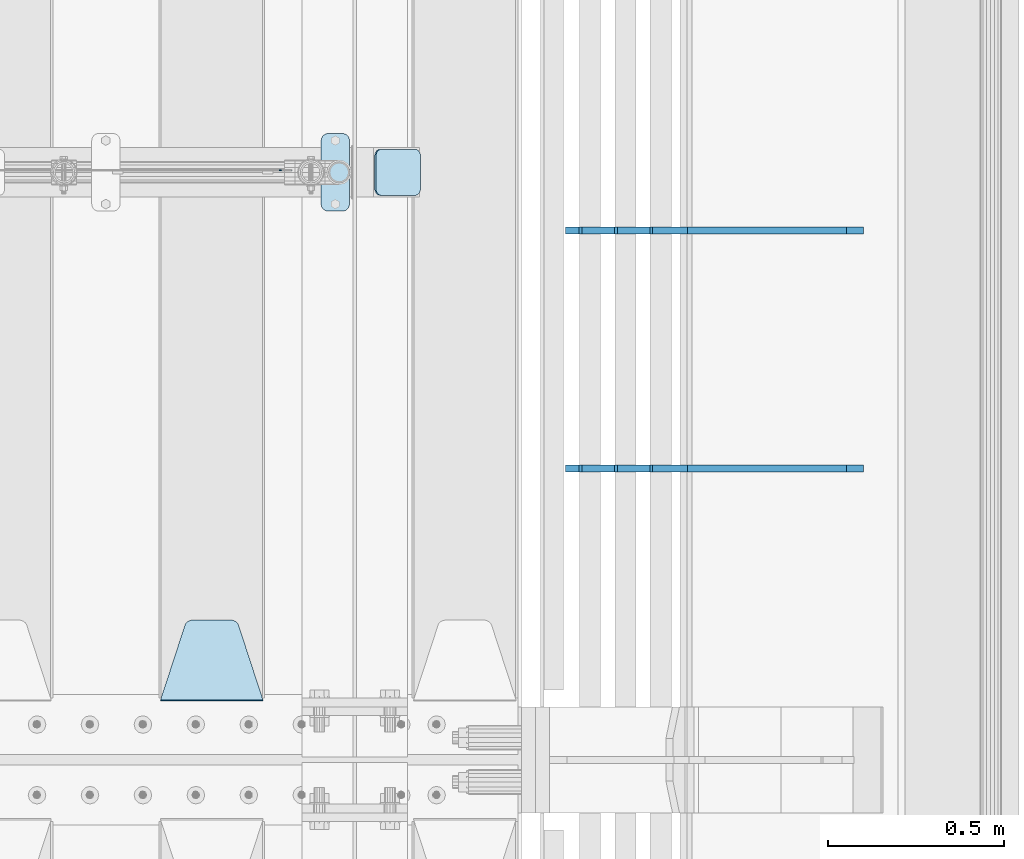
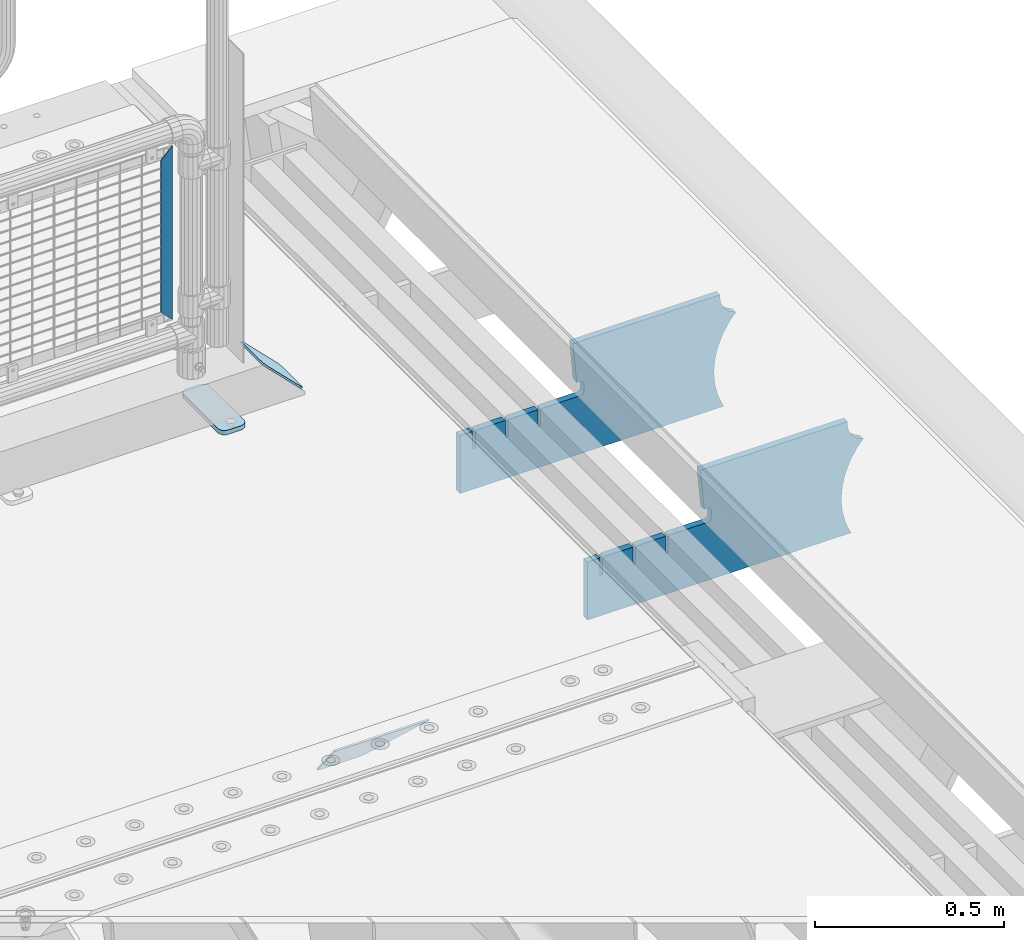
# One storey, part 223 of 240: 6 plates.
"""IFC2X3 building model written with IfcOpenShell, lengths in millimetres."""

from ifc_helpers import new_model, si_unit, frame, origin_with_axes, place, context, subcontext, project, spatial, faceted_brep, material, type_object, element, save


model = new_model("IFC2X3")

# Units and contexts
model_context = context("Model", 3, precision=1e-05, world=origin_with_axes())
body_context = subcontext(model_context, "Body", "Model", "MODEL_VIEW")
ifc_project = project(units=[si_unit("LENGTHUNIT", "METRE", prefix="MILLI"), si_unit("AREAUNIT", "SQUARE_METRE"), si_unit("VOLUMEUNIT", "CUBIC_METRE"), si_unit("MASSUNIT", "GRAM", prefix="KILO"), si_unit("TIMEUNIT", "SECOND"), si_unit("PLANEANGLEUNIT", "RADIAN"), si_unit("SOLIDANGLEUNIT", "STERADIAN"), si_unit("THERMODYNAMICTEMPERATUREUNIT", "DEGREE_CELSIUS"), si_unit("LUMINOUSINTENSITYUNIT", "LUMEN")], contexts=[model_context])

# Site, building, storey
site_placement = place(None, origin_with_axes())
site = spatial("IfcSite", under=ifc_project, at=site_placement, CompositionType="ELEMENT")
building_placement = place(site_placement, origin_with_axes())
building = spatial("IfcBuilding", under=site, at=building_placement, Name="Standard", CompositionType="ELEMENT")
storey_placement = place(building_placement, origin_with_axes())
storey = spatial("IfcBuildingStorey", under=building, at=storey_placement, Name="Undefined", CompositionType="ELEMENT", Elevation=0.0)

# Plates
ifc_material_1 = material(Name="STEEL/S355N")
plate_type_1 = type_object("IfcPlateType", PredefinedType="NOTDEFINED")
plate_1_placement = place(storey_placement, frame((55745.0, 33168.232233047, -1.76776695296758), z_axis=(0.0, 0.707106781186547, -0.707106781186548), x_axis=(-1.0, 0.0, 0.0)))
element("IfcPlate", 1, at=plate_1_placement, inside=storey, type_object=plate_type_1, material=ifc_material_1, context=body_context, shape_type="Brep", body=[
    faceted_brep([(0.0, -2.5, 0.0), (69.345504679477, -2.50000000000364, 300.171731424827), (69.345504679477, 2.49999999999636, 300.171731424827), (0.0, 2.5, 0.0), (70.927406119954, -2.50000000000364, 304.897442415397), (70.927406119954, 2.49999999999636, 304.897442415397), (73.3818627772271, -2.50000000000728, 309.234538108525), (73.3818627772271, 2.49999999999636, 309.234538108529), (76.6187032999587, -2.50000000000728, 313.023683126099), (76.6187032999587, 2.49999999999636, 313.023683126103), (80.5190132705029, -2.50000000000364, 316.125672595368), (80.5190132705029, 2.49999999999636, 316.125672595368), (84.9395038596849, -2.50000000000364, 318.426546230472), (84.9395038596849, 2.49999999999636, 318.426546230472), (89.7177759439219, -2.5, 319.841774983277), (89.7177759439219, 2.49999999999636, 319.841774983273), (94.6782862926484, -2.50000000000364, 320.319366455074), (94.6782862926484, 2.49999999999636, 320.319366455074), (195.321713707352, -2.50000000000364, 320.319366455074), (195.321713707352, 2.49999999999636, 320.319366455074), (200.282224056078, -2.50000000000364, 319.841774983273), (200.282224056078, 2.49999999999636, 319.841774983273), (205.060496140315, -2.50000000000364, 318.426546230472), (205.060496140315, 2.49999999999636, 318.426546230472), (209.480986729497, -2.50000000000364, 316.125672595368), (209.480986729497, 2.49999999999636, 316.125672595368), (213.381296700041, -2.50000000000728, 313.023683126099), (213.381296700041, 2.49999999999272, 313.023683126099), (216.618137222766, -2.50000000000364, 309.234538108522), (216.618137222766, 2.49999999999636, 309.234538108522), (219.072593880039, -2.50000000000364, 304.897442415397), (219.072593880039, 2.49999999999636, 304.897442415397), (220.654495320523, -2.50000000000364, 300.171731424827), (220.654495320523, 2.49999999999636, 300.171731424827), (290.0, -2.50000000000364, -3.63797880709171e-12), (290.0, 2.49999999999636, -3.63797880709171e-12)], [[[0, 1, 2, 3]], [[1, 4, 5, 2]], [[4, 6, 7, 5]], [[6, 8, 9, 7]], [[8, 10, 11, 9]], [[10, 12, 13, 11]], [[12, 14, 15, 13]], [[14, 16, 17, 15]], [[16, 18, 19, 17]], [[18, 20, 21, 19]], [[20, 22, 23, 21]], [[22, 24, 25, 23]], [[24, 26, 27, 25]], [[26, 28, 29, 27]], [[28, 30, 31, 29]], [[30, 32, 33, 31]], [[32, 34, 35, 33]], [[34, 0, 3, 35]], [[5, 7, 9, 11, 13, 15, 17, 19, 21, 23, 25, 27, 29, 31, 33, 35, 3, 2]], [[34, 32, 30, 28, 26, 24, 22, 20, 18, 16, 14, 12, 10, 8, 6, 4, 1, 0]]]),
])
ifc_material_2 = material(Name="STEEL/S355J2")
plate_type_2 = type_object("IfcPlateType", PredefinedType="NOTDEFINED")
plate_2_placement = place(storey_placement, frame((55910.0, 34774.5, 21.0199999999977), z_axis=(1.0, 0.0, 0.0), x_axis=(0.0, -1.0, 0.0)))
element("IfcPlate", 2, at=plate_2_placement, inside=storey, type_object=plate_type_2, material=ifc_material_2, context=body_context, shape_type="Brep", body=[
    faceted_brep([(0.0, -7.0, 20.0), (0.0, -7.0, 60.0), (0.0, 7.0, 60.0), (0.0, 7.0, 20.0), (0.384294391937146, -7.0, 63.9018064403208), (0.384294391937146, 7.0, 63.9018064403208), (1.52240934977453, -7.0, 67.6536686473046), (1.52240934977453, 7.0, 67.6536686473046), (3.37060775394639, -7.0, 71.1114046603907), (3.37060775394639, 7.0, 71.1114046603907), (5.85786437626666, -7.0, 74.1421356237333), (5.85786437626666, 7.0, 74.1421356237333), (8.88859533960931, -7.0, 76.6293922460536), (8.88859533960931, 7.0, 76.6293922460536), (12.3463313526954, -7.0, 78.4775906502255), (12.3463313526954, 7.0, 78.4775906502255), (16.0981935596792, -7.0, 79.6157056080629), (16.0981935596792, 7.0, 79.6157056080629), (20.0, -7.0, 80.0), (20.0, 7.0, 80.0), (200.0, -7.0, 80.0), (200.0, 7.0, 80.0), (203.901806440321, -7.0, 79.6157056080629), (203.901806440321, 7.0, 79.6157056080629), (207.653668647305, -7.0, 78.4775906502255), (207.653668647305, 7.0, 78.4775906502255), (211.111404660391, -7.0, 76.6293922460536), (211.111404660391, 7.0, 76.6293922460536), (214.142135623733, -7.0, 74.1421356237333), (214.142135623733, 7.0, 74.1421356237333), (216.629392246054, -7.0, 71.1114046603907), (216.629392246054, 7.0, 71.1114046603907), (218.477590650225, -7.0, 67.6536686473046), (218.477590650225, 7.0, 67.6536686473046), (219.615705608063, -7.0, 63.9018064403208), (219.615705608063, 7.0, 63.9018064403208), (220.0, -7.0, 60.0), (220.0, 7.0, 60.0), (220.0, -7.0, 20.0), (220.0, 7.0, 20.0), (219.615705608063, -7.0, 16.0981935596792), (219.615705608063, 7.0, 16.0981935596792), (218.477590650225, -7.0, 12.3463313526954), (218.477590650225, 7.0, 12.3463313526954), (216.629392246054, -7.0, 8.88859533960931), (216.629392246054, 7.0, 8.88859533960931), (214.142135623733, -7.0, 5.85786437626666), (214.142135623733, 7.0, 5.85786437626666), (211.111404660391, -7.0, 3.37060775394639), (211.111404660391, 7.0, 3.37060775394639), (207.653668647305, -7.0, 1.52240934977453), (207.653668647305, 7.0, 1.52240934977453), (203.901806440321, -7.0, 0.384294391937146), (203.901806440321, 7.0, 0.384294391937146), (200.0, -7.0, 0.0), (200.0, 7.0, 0.0), (20.0, -7.0, 0.0), (20.0, 7.0, 0.0), (16.0981935596792, -7.0, 0.384294391937146), (16.0981935596792, 7.0, 0.384294391937146), (12.3463313526954, -7.0, 1.52240934977453), (12.3463313526954, 7.0, 1.52240934977453), (8.88859533960931, -7.0, 3.37060775394639), (8.88859533960931, 7.0, 3.37060775394639), (5.85786437626666, -7.0, 5.85786437626666), (5.85786437626666, 7.0, 5.85786437626666), (3.37060775394639, -7.0, 8.88859533960931), (3.37060775394639, 7.0, 8.88859533960931), (1.52240934977453, -7.0, 12.3463313526954), (1.52240934977453, 7.0, 12.3463313526954), (0.384294391937146, -7.0, 16.0981935596792), (0.384294391937146, 7.0, 16.0981935596792)], [[[0, 1, 2, 3]], [[1, 4, 5, 2]], [[4, 6, 7, 5]], [[6, 8, 9, 7]], [[8, 10, 11, 9]], [[10, 12, 13, 11]], [[12, 14, 15, 13]], [[14, 16, 17, 15]], [[16, 18, 19, 17]], [[18, 20, 21, 19]], [[20, 22, 23, 21]], [[22, 24, 25, 23]], [[24, 26, 27, 25]], [[26, 28, 29, 27]], [[28, 30, 31, 29]], [[30, 32, 33, 31]], [[32, 34, 35, 33]], [[34, 36, 37, 35]], [[36, 38, 39, 37]], [[38, 40, 41, 39]], [[40, 42, 43, 41]], [[42, 44, 45, 43]], [[44, 46, 47, 45]], [[46, 48, 49, 47]], [[48, 50, 51, 49]], [[50, 52, 53, 51]], [[52, 54, 55, 53]], [[54, 56, 57, 55]], [[56, 58, 59, 57]], [[58, 60, 61, 59]], [[60, 62, 63, 61]], [[62, 64, 65, 63]], [[64, 66, 67, 65]], [[66, 68, 69, 67]], [[68, 70, 71, 69]], [[70, 0, 3, 71]], [[5, 7, 9, 11, 13, 15, 17, 19, 21, 23, 25, 27, 29, 31, 33, 35, 37, 39, 41, 43, 45, 47, 49, 51, 53, 55, 57, 59, 61, 63, 65, 67, 69, 71, 3, 2]], [[70, 68, 66, 64, 62, 60, 58, 56, 54, 52, 50, 48, 46, 44, 42, 40, 38, 36, 34, 32, 30, 28, 26, 24, 22, 20, 18, 16, 14, 12, 10, 8, 6, 4, 1, 0]]]),
])
plate_type_3 = type_object("IfcPlateType", PredefinedType="NOTDEFINED")
plate_3_placement = place(storey_placement, frame((56063.1924184789, 34729.5, 166.254400376664), z_axis=(0.707410512925779, 0.0, -0.70680291892584), x_axis=(0.0, -1.0, 0.0)))
element("IfcPlate", 3, at=plate_3_placement, inside=storey, type_object=plate_type_3, material=ifc_material_2, context=body_context, shape_type="Brep", body=[
    faceted_brep([(0.0, -2.5, 20.0), (0.0, -2.5, 158.926651000977), (0.0, 2.50000000000728, 158.926651000969), (0.0, 2.5, 19.9999999999927), (0.384294391937146, -2.50000000000728, 162.828457441297), (0.384294391937146, 2.5, 162.828457441297), (1.52240934977453, -2.5, 166.580319648274), (1.52240934977453, 2.50000000000728, 166.580319648274), (3.37060775394639, -2.5, 170.038055661367), (3.37060775394639, 2.5, 170.038055661367), (5.85786437626666, -2.49999999999272, 173.068786624703), (5.85786437626666, 2.5, 173.068786624703), (8.88859533960931, -2.5, 175.556043247023), (8.88859533960931, 2.50000000000728, 175.556043247023), (12.3463313526954, -2.5, 177.404241651195), (12.3463313526954, 2.50000000000728, 177.404241651195), (16.0981935596792, -2.5, 178.542356609039), (16.0981935596792, 2.50000000000728, 178.542356609039), (20.0, -2.5, 178.926651000977), (20.0, 2.5, 178.926651000977), (110.0, -2.5, 178.926651000977), (110.0, 2.5, 178.926651000977), (113.901806440321, -2.5, 178.542356609039), (113.901806440321, 2.50000000000728, 178.542356609039), (117.653668647305, -2.5, 177.404241651195), (117.653668647305, 2.50000000000728, 177.404241651195), (121.111404660391, -2.5, 175.556043247023), (121.111404660391, 2.50000000000728, 175.556043247023), (124.142135623733, -2.49999999999272, 173.068786624703), (124.142135623733, 2.5, 173.068786624703), (126.629392246054, -2.5, 170.038055661367), (126.629392246054, 2.5, 170.038055661367), (128.477590650225, -2.5, 166.580319648274), (128.477590650225, 2.50000000000728, 166.580319648274), (129.615705608063, -2.50000000000728, 162.828457441297), (129.615705608063, 2.5, 162.828457441297), (130.0, -2.5, 158.926651000977), (130.0, 2.50000000000728, 158.926651000969), (130.0, -2.5, 20.0), (130.0, 2.5, 19.9999999999927), (129.615705608063, -2.5, 16.0981935596719), (129.615705608063, 2.50000000000728, 16.0981935596719), (128.477590650225, -2.50000000000728, 12.3463313527027), (128.477590650225, 2.5, 12.3463313526954), (126.629392246054, -2.49999999999272, 8.88859533960931), (126.629392246054, 2.5, 8.88859533960931), (124.142135623733, -2.49999999999272, 5.85786437626666), (124.142135623733, 2.5, 5.85786437626666), (121.111404660391, -2.5, 3.37060775394639), (121.111404660391, 2.5, 3.37060775393911), (117.653668647305, -2.5, 1.52240934976726), (117.653668647305, 2.5, 1.52240934977453), (113.901806440321, -2.5, 0.38429439192987), (113.901806440321, 2.5, 0.38429439192987), (110.0, -2.5, 0.0), (110.0, 2.5, 0.0), (20.0, -2.5, 0.0), (20.0, 2.5, 0.0), (16.0981935596792, -2.5, 0.38429439192987), (16.0981935596792, 2.5, 0.38429439192987), (12.3463313526954, -2.5, 1.52240934976726), (12.3463313526954, 2.5, 1.52240934977453), (8.88859533960931, -2.5, 3.37060775394639), (8.88859533960931, 2.5, 3.37060775393911), (5.85786437626666, -2.49999999999272, 5.85786437626666), (5.85786437626666, 2.5, 5.85786437626666), (3.37060775394639, -2.49999999999272, 8.88859533960931), (3.37060775394639, 2.5, 8.88859533960931), (1.52240934977453, -2.5, 12.3463313526954), (1.52240934977453, 2.5, 12.3463313526954), (0.384294391937146, -2.5, 16.0981935596719), (0.384294391937146, 2.50000000000728, 16.0981935596719)], [[[0, 1, 2, 3]], [[1, 4, 5, 2]], [[4, 6, 7, 5]], [[6, 8, 9, 7]], [[8, 10, 11, 9]], [[10, 12, 13, 11]], [[12, 14, 15, 13]], [[14, 16, 17, 15]], [[16, 18, 19, 17]], [[18, 20, 21, 19]], [[20, 22, 23, 21]], [[22, 24, 25, 23]], [[24, 26, 27, 25]], [[26, 28, 29, 27]], [[28, 30, 31, 29]], [[30, 32, 33, 31]], [[32, 34, 35, 33]], [[34, 36, 37, 35]], [[36, 38, 39, 37]], [[38, 40, 41, 39]], [[40, 42, 43, 41]], [[42, 44, 45, 43]], [[44, 46, 47, 45]], [[46, 48, 49, 47]], [[48, 50, 51, 49]], [[50, 52, 53, 51]], [[52, 54, 55, 53]], [[54, 56, 57, 55]], [[56, 58, 59, 57]], [[58, 60, 61, 59]], [[60, 62, 63, 61]], [[62, 64, 65, 63]], [[64, 66, 67, 65]], [[66, 68, 69, 67]], [[68, 70, 71, 69]], [[70, 0, 3, 71]], [[5, 7, 9, 11, 13, 15, 17, 19, 21, 23, 25, 27, 29, 31, 33, 35, 37, 39, 41, 43, 45, 47, 49, 51, 53, 55, 57, 59, 61, 63, 65, 67, 69, 71, 3, 2]], [[70, 68, 66, 64, 62, 60, 58, 56, 54, 52, 50, 48, 46, 44, 42, 40, 38, 36, 34, 32, 30, 28, 26, 24, 22, 20, 18, 16, 14, 12, 10, 8, 6, 4, 1, 0]]]),
])
ifc_material_3 = material(Name="Misc_Undefined")
plate_type_4 = type_object("IfcPlateType", PredefinedType="NOTDEFINED")
plate_4_placement = place(storey_placement, frame((55826.4999999862, 34670.4997788013, 914.461469028507), z_axis=(0.706514791587334, 1.29999971174141e-08, -0.707698275586641), x_axis=(-0.707698275586609, 0.0, -0.706514791587367)))
element("IfcPlate", 4, at=plate_4_placement, inside=storey, type_object=plate_type_4, material=ifc_material_3, context=body_context, shape_type="Brep", body=[
    faceted_brep([(-7.27595761418343e-12, -1.49999999999272, 0.0), (397.726470947244, -1.5, 398.39270019532), (397.726470947237, 1.5, 398.392700195313), (0.0, 1.50000000000728, 0.0), (397.767883300759, -1.5, 348.895263671875), (397.767883300759, 1.5, 348.895263671875), (49.4561042785572, -1.5, -5.0931703299284e-11), (49.4561042785572, 1.5, -5.0931703299284e-11)], [[[0, 1, 2, 3]], [[1, 4, 5, 2]], [[4, 6, 7, 5]], [[6, 0, 3, 7]], [[5, 7, 3, 2]], [[6, 4, 1, 0]]]),
])
plate_type_5 = type_object("IfcPlateType", PredefinedType="NOTDEFINED")
plate_5_placement = place(storey_placement, frame((57442.9182339676, 33824.9992828369, -374.002067436516), z_axis=(0.0, 0.0, 1.0), x_axis=(-1.0, 0.0, 0.0)))
element("IfcPlate", 5, at=plate_5_placement, inside=storey, type_object=plate_type_5, material=ifc_material_1, context=body_context, shape_type="Brep", body=[
    faceted_brep([(801.919404066546, -10.0, 188.0), (801.919404066546, 10.0, 188.0), (801.919404066546, 10.0, 132.002067436952), (801.919404066546, -10.0, 132.002067436952), (793.919404066546, 10.0, 132.002067436952), (793.919404066546, -10.0, 132.002067436952), (793.919404066546, 10.0, 180.002067436952), (793.919404066546, -10.0, 180.002067436952), (793.52785619691, 10.0, 182.474203391951), (793.52785619691, -10.0, 182.474203391951), (792.391540021548, 10.0, 184.704349455291), (792.391540021548, -10.0, 184.704349455291), (790.621686084887, 10.0, 186.474203391951), (790.621686084887, -10.0, 186.474203391951), (788.391540021548, 10.0, 187.610519567313), (788.391540021548, -10.0, 187.610519567313), (785.919404066546, -10.0, 188.002067436952), (785.919404066546, 10.0, 188.0), (841.0, -10.0, 188.0), (841.0, -10.0, 0.0), (841.0, 10.0, 0.0), (841.0, 10.0, 188.0), (33.3619566735943, -10.0, 0.0), (33.3619566735943, 10.0, 0.0), (36.2350612208102, -10.0, 4.68848050267013), (36.2350612208102, 10.0, 4.68848050267013), (51.4877592159319, -10.0, 41.5117508652784), (51.4877592159319, 10.0, 41.5117508652784), (60.7922425881334, -10.0, 80.2677133162964), (60.7922425881334, 10.0, 80.2677133162964), (63.9194040769653, -10.0, 120.002067436515), (63.9194040769653, 10.0, 120.002067436515), (60.7922425881334, -10.0, 159.736421556734), (60.7922425881334, 10.0, 159.736421556734), (51.4877592159319, -10.0, 198.492384007752), (51.4877592159319, 10.0, 198.492384007752), (36.2350612208102, -10.0, 235.31565437036), (36.2350612208102, 10.0, 235.31565437036), (15.4097206482038, -10.0, 269.299521518803), (15.4097206482038, 10.0, 269.299521518803), (-3.35474438100209, -10.0, 291.269887256574), (-3.35474438100209, 10.0, 291.269887256574), (-2.36881039375294, -10.0000000000036, 291.426043859339), (-2.36881039375294, 10.0, 291.426043859339), (17.1449676604752, -10.0000000000036, 301.368810393754), (17.1449676604752, 10.0, 301.368810393754), (32.6311896062471, -10.0000000000036, 316.855032339527), (32.6311896062471, 10.0, 316.855032339527), (42.573956140659, -10.0000000000036, 336.368810393754), (42.573956140659, 10.0, 336.368810393754), (46.0, -10.0000000000036, 358.0), (46.0, 10.0, 358.0), (45.0495205499246, -10.0, 364.001091067617), (45.0495205499246, 10.0, 364.001091067617), (495.040008544922, -10.0, 364.010009765625), (495.040008544922, 10.0, 364.010009765625), (483.600036621094, -10.0, 233.759994506836), (483.600036621094, 10.0, 233.759994506836), (472.0, -10.0, 233.759994506836), (472.0, 10.0, 233.759994506836), (468.909830056247, -10.0, 233.270559669787), (468.909830056247, 10.0, 233.270559669787), (466.122147477072, -10.0, 231.850164450585), (466.122147477072, 10.0, 231.850164450585), (463.909830056247, -10.0, 229.637847029761), (463.909830056247, 10.0, 229.637847029761), (462.489434837051, -10.0, 226.850164450585), (462.489434837051, 10.0, 226.850164450585), (462.0, -10.0, 223.759994506836), (462.0, 10.0, 223.759994506836), (462.0, -10.0, 198.0), (462.0, 10.0, 198.0), (462.489434837051, -10.0, 194.909830056251), (462.489434837051, 10.0, 194.909830056251), (463.909830056247, -10.0, 192.122147477075), (463.909830056247, 10.0, 192.122147477075), (466.122147477072, -10.0, 189.909830056251), (466.122147477072, 10.0, 189.909830056251), (468.909830056247, -10.0, 188.489434837048), (468.909830056247, 10.0, 188.489434837048), (472.0, -10.0, 188.0), (472.0, 10.0, 188.0), (585.919404066546, -10.0, 188.002067436952), (585.919404066546, 10.0, 188.0), (588.391540021548, -9.99999999999636, 187.610519567313), (588.391540021548, 10.0, 187.610519567313), (590.621686084887, -9.99999999999636, 186.474203391951), (590.621686084887, 10.0, 186.474203391951), (592.391540021548, -9.99999999999636, 184.704349455291), (592.391540021548, 10.0, 184.704349455291), (593.52785619691, -9.99999999999636, 182.474203391951), (593.52785619691, 10.0, 182.474203391951), (593.919404066546, -9.99999999999636, 180.002067436952), (593.919404066546, 10.0, 180.002067436952), (593.919404066546, -9.99999999999636, 132.002067436952), (593.919404066546, 10.0, 132.002067436952), (601.919404066546, -9.99999999999636, 132.002067436952), (601.919404066546, 10.0, 132.002067436952), (601.919404066546, -10.0, 188.0), (601.919404066546, 10.0, 188.0), (685.919404066546, -10.0, 188.002067436952), (685.919404066546, 10.0, 188.0), (688.391540021548, -10.0, 187.610519567313), (688.391540021548, 10.0, 187.610519567313), (690.621686084887, -10.0, 186.474203391951), (690.621686084887, 10.0, 186.474203391951), (692.391540021548, -10.0, 184.704349455291), (692.391540021548, 10.0, 184.704349455291), (693.52785619691, -10.0, 182.474203391951), (693.52785619691, 10.0, 182.474203391951), (693.919404066546, -10.0, 180.002067436952), (693.919404066546, 10.0, 180.002067436952), (693.919404066546, -10.0, 132.002067436952), (693.919404066546, 10.0000000000036, 132.002067436952), (701.919404066546, -10.0, 132.002067436952), (701.919404066546, 10.0000000000036, 132.002067436952), (701.919404066546, -10.0, 188.0), (701.919404066546, 10.0, 188.0)], [[[0, 1, 2, 3]], [[3, 2, 4, 5]], [[5, 4, 6, 7]], [[7, 6, 8, 9]], [[9, 8, 10, 11]], [[11, 10, 12, 13]], [[13, 12, 14, 15]], [[16, 15, 14, 17]], [[18, 19, 20, 21]], [[20, 19, 22, 23]], [[22, 24, 25, 23]], [[26, 27, 25, 24]], [[28, 29, 27, 26]], [[30, 31, 29, 28]], [[32, 33, 31, 30]], [[34, 35, 33, 32]], [[36, 37, 35, 34]], [[38, 39, 37, 36]], [[39, 38, 40, 41]], [[40, 42, 43, 41]], [[44, 45, 43, 42]], [[46, 47, 45, 44]], [[48, 49, 47, 46]], [[50, 51, 49, 48]], [[52, 53, 51, 50]], [[54, 55, 53, 52]], [[54, 56, 57, 55]], [[56, 58, 59, 57]], [[58, 60, 61, 59]], [[60, 62, 63, 61]], [[62, 64, 65, 63]], [[64, 66, 67, 65]], [[66, 68, 69, 67]], [[68, 70, 71, 69]], [[70, 72, 73, 71]], [[72, 74, 75, 73]], [[74, 76, 77, 75]], [[76, 78, 79, 77]], [[78, 80, 81, 79]], [[81, 80, 82, 83]], [[82, 84, 85, 83]], [[86, 87, 85, 84]], [[88, 89, 87, 86]], [[90, 91, 89, 88]], [[92, 93, 91, 90]], [[94, 95, 93, 92]], [[96, 97, 95, 94]], [[98, 99, 97, 96]], [[99, 98, 100, 101]], [[100, 102, 103, 101]], [[104, 105, 103, 102]], [[106, 107, 105, 104]], [[108, 109, 107, 106]], [[110, 111, 109, 108]], [[112, 113, 111, 110]], [[114, 115, 113, 112]], [[116, 117, 115, 114]], [[117, 116, 16, 17]], [[12, 10, 8, 6, 4, 2, 1, 21, 20, 23, 25, 27, 29, 31, 33, 35, 37, 39, 41, 43, 45, 47, 49, 51, 53, 55, 57, 59, 61, 63, 65, 67, 69, 71, 73, 75, 77, 79, 81, 83, 85, 87, 89, 91, 93, 95, 97, 99, 101, 103, 105, 107, 109, 111, 113, 115, 117, 17, 14]], [[18, 21, 1, 0]], [[116, 114, 112, 110, 108, 106, 104, 102, 100, 98, 96, 94, 92, 90, 88, 86, 84, 82, 80, 78, 76, 74, 72, 70, 68, 66, 64, 62, 60, 58, 56, 54, 52, 50, 48, 46, 44, 42, 40, 38, 36, 34, 32, 30, 28, 26, 24, 22, 19, 18, 0, 3, 5, 7, 9, 11, 13, 15, 16]]]),
])
plate_6_placement = place(storey_placement, frame((57442.9182339676, 34499.9992828369, -374.002067436516), z_axis=(0.0, 0.0, 1.0), x_axis=(-1.0, 0.0, 0.0)))
element("IfcPlate", 6, at=plate_6_placement, inside=storey, type_object=plate_type_5, material=ifc_material_1, context=body_context, shape_type="Brep", body=[
    faceted_brep([(801.919404066546, -10.0, 188.0), (801.919404066546, 10.0, 188.0), (801.919404066546, 10.0, 132.002067436952), (801.919404066546, -10.0, 132.002067436952), (793.919404066546, 10.0, 132.002067436952), (793.919404066546, -10.0, 132.002067436952), (793.919404066546, 10.0, 180.002067436952), (793.919404066546, -10.0, 180.002067436952), (793.52785619691, 10.0, 182.474203391951), (793.52785619691, -10.0, 182.474203391951), (792.391540021548, 10.0, 184.704349455291), (792.391540021548, -10.0, 184.704349455291), (790.621686084887, 10.0, 186.474203391951), (790.621686084887, -10.0, 186.474203391951), (788.391540021548, 10.0, 187.610519567313), (788.391540021548, -10.0, 187.610519567313), (785.919404066546, -10.0, 188.002067436952), (785.919404066546, 10.0, 188.0), (841.0, -10.0, 188.0), (841.0, -10.0, 0.0), (841.0, 10.0, 0.0), (841.0, 10.0, 188.0), (33.3619566735943, -10.0, 0.0), (33.3619566735943, 10.0, 0.0), (36.2350612208102, -10.0, 4.68848050267013), (36.2350612208102, 10.0, 4.68848050267013), (51.4877592159319, -10.0, 41.5117508652784), (51.4877592159319, 10.0, 41.5117508652784), (60.7922425881334, -10.0, 80.2677133162964), (60.7922425881334, 10.0, 80.2677133162964), (63.9194040769653, -10.0, 120.002067436515), (63.9194040769653, 10.0, 120.002067436515), (60.7922425881334, -10.0, 159.736421556734), (60.7922425881334, 10.0, 159.736421556734), (51.4877592159319, -10.0, 198.492384007752), (51.4877592159319, 10.0, 198.492384007752), (36.2350612208102, -10.0, 235.31565437036), (36.2350612208102, 10.0, 235.31565437036), (15.4097206482038, -10.0, 269.299521518803), (15.4097206482038, 10.0, 269.299521518803), (-3.35474438100209, -10.0, 291.269887256574), (-3.35474438100209, 10.0, 291.269887256574), (-2.36881039375294, -10.0000000000036, 291.426043859339), (-2.36881039375294, 10.0, 291.426043859339), (17.1449676604752, -10.0000000000036, 301.368810393754), (17.1449676604752, 10.0, 301.368810393754), (32.6311896062471, -10.0000000000036, 316.855032339527), (32.6311896062471, 10.0, 316.855032339527), (42.573956140659, -10.0000000000036, 336.368810393754), (42.573956140659, 10.0, 336.368810393754), (46.0, -10.0000000000036, 358.0), (46.0, 10.0, 358.0), (45.0495205499246, -10.0, 364.001091067617), (45.0495205499246, 10.0, 364.001091067617), (495.040008544922, -10.0, 364.010009765625), (495.040008544922, 10.0, 364.010009765625), (483.600036621094, -10.0, 233.759994506836), (483.600036621094, 10.0, 233.759994506836), (472.0, -10.0, 233.759994506836), (472.0, 10.0, 233.759994506836), (468.909830056247, -10.0, 233.270559669787), (468.909830056247, 10.0, 233.270559669787), (466.122147477072, -10.0, 231.850164450585), (466.122147477072, 10.0, 231.850164450585), (463.909830056247, -10.0, 229.637847029761), (463.909830056247, 10.0, 229.637847029761), (462.489434837051, -10.0, 226.850164450585), (462.489434837051, 10.0, 226.850164450585), (462.0, -10.0, 223.759994506836), (462.0, 10.0, 223.759994506836), (462.0, -10.0, 198.0), (462.0, 10.0, 198.0), (462.489434837051, -10.0, 194.909830056251), (462.489434837051, 10.0, 194.909830056251), (463.909830056247, -10.0, 192.122147477075), (463.909830056247, 10.0, 192.122147477075), (466.122147477072, -10.0, 189.909830056251), (466.122147477072, 10.0, 189.909830056251), (468.909830056247, -10.0, 188.489434837048), (468.909830056247, 10.0, 188.489434837048), (472.0, -10.0, 188.0), (472.0, 10.0, 188.0), (585.919404066546, -10.0, 188.002067436952), (585.919404066546, 10.0, 188.0), (588.391540021548, -9.99999999999636, 187.610519567313), (588.391540021548, 10.0, 187.610519567313), (590.621686084887, -9.99999999999636, 186.474203391951), (590.621686084887, 10.0, 186.474203391951), (592.391540021548, -9.99999999999636, 184.704349455291), (592.391540021548, 10.0, 184.704349455291), (593.52785619691, -9.99999999999636, 182.474203391951), (593.52785619691, 10.0, 182.474203391951), (593.919404066546, -9.99999999999636, 180.002067436952), (593.919404066546, 10.0, 180.002067436952), (593.919404066546, -9.99999999999636, 132.002067436952), (593.919404066546, 10.0, 132.002067436952), (601.919404066546, -9.99999999999636, 132.002067436952), (601.919404066546, 10.0, 132.002067436952), (601.919404066546, -10.0, 188.0), (601.919404066546, 10.0, 188.0), (685.919404066546, -10.0, 188.002067436952), (685.919404066546, 10.0, 188.0), (688.391540021548, -10.0, 187.610519567313), (688.391540021548, 10.0, 187.610519567313), (690.621686084887, -10.0, 186.474203391951), (690.621686084887, 10.0, 186.474203391951), (692.391540021548, -10.0, 184.704349455291), (692.391540021548, 10.0, 184.704349455291), (693.52785619691, -10.0, 182.474203391951), (693.52785619691, 10.0, 182.474203391951), (693.919404066546, -10.0, 180.002067436952), (693.919404066546, 10.0, 180.002067436952), (693.919404066546, -10.0, 132.002067436952), (693.919404066546, 10.0000000000036, 132.002067436952), (701.919404066546, -10.0, 132.002067436952), (701.919404066546, 10.0000000000036, 132.002067436952), (701.919404066546, -10.0, 188.0), (701.919404066546, 10.0, 188.0)], [[[0, 1, 2, 3]], [[3, 2, 4, 5]], [[5, 4, 6, 7]], [[7, 6, 8, 9]], [[9, 8, 10, 11]], [[11, 10, 12, 13]], [[13, 12, 14, 15]], [[16, 15, 14, 17]], [[18, 19, 20, 21]], [[20, 19, 22, 23]], [[22, 24, 25, 23]], [[26, 27, 25, 24]], [[28, 29, 27, 26]], [[30, 31, 29, 28]], [[32, 33, 31, 30]], [[34, 35, 33, 32]], [[36, 37, 35, 34]], [[38, 39, 37, 36]], [[39, 38, 40, 41]], [[40, 42, 43, 41]], [[44, 45, 43, 42]], [[46, 47, 45, 44]], [[48, 49, 47, 46]], [[50, 51, 49, 48]], [[52, 53, 51, 50]], [[54, 55, 53, 52]], [[54, 56, 57, 55]], [[56, 58, 59, 57]], [[58, 60, 61, 59]], [[60, 62, 63, 61]], [[62, 64, 65, 63]], [[64, 66, 67, 65]], [[66, 68, 69, 67]], [[68, 70, 71, 69]], [[70, 72, 73, 71]], [[72, 74, 75, 73]], [[74, 76, 77, 75]], [[76, 78, 79, 77]], [[78, 80, 81, 79]], [[81, 80, 82, 83]], [[82, 84, 85, 83]], [[86, 87, 85, 84]], [[88, 89, 87, 86]], [[90, 91, 89, 88]], [[92, 93, 91, 90]], [[94, 95, 93, 92]], [[96, 97, 95, 94]], [[98, 99, 97, 96]], [[99, 98, 100, 101]], [[100, 102, 103, 101]], [[104, 105, 103, 102]], [[106, 107, 105, 104]], [[108, 109, 107, 106]], [[110, 111, 109, 108]], [[112, 113, 111, 110]], [[114, 115, 113, 112]], [[116, 117, 115, 114]], [[117, 116, 16, 17]], [[12, 10, 8, 6, 4, 2, 1, 21, 20, 23, 25, 27, 29, 31, 33, 35, 37, 39, 41, 43, 45, 47, 49, 51, 53, 55, 57, 59, 61, 63, 65, 67, 69, 71, 73, 75, 77, 79, 81, 83, 85, 87, 89, 91, 93, 95, 97, 99, 101, 103, 105, 107, 109, 111, 113, 115, 117, 17, 14]], [[18, 21, 1, 0]], [[116, 114, 112, 110, 108, 106, 104, 102, 100, 98, 96, 94, 92, 90, 88, 86, 84, 82, 80, 78, 76, 74, 72, 70, 68, 66, 64, 62, 60, 58, 56, 54, 52, 50, 48, 46, 44, 42, 40, 38, 36, 34, 32, 30, 28, 26, 24, 22, 19, 18, 0, 3, 5, 7, 9, 11, 13, 15, 16]]]),
])

save(model, "model.ifc")
